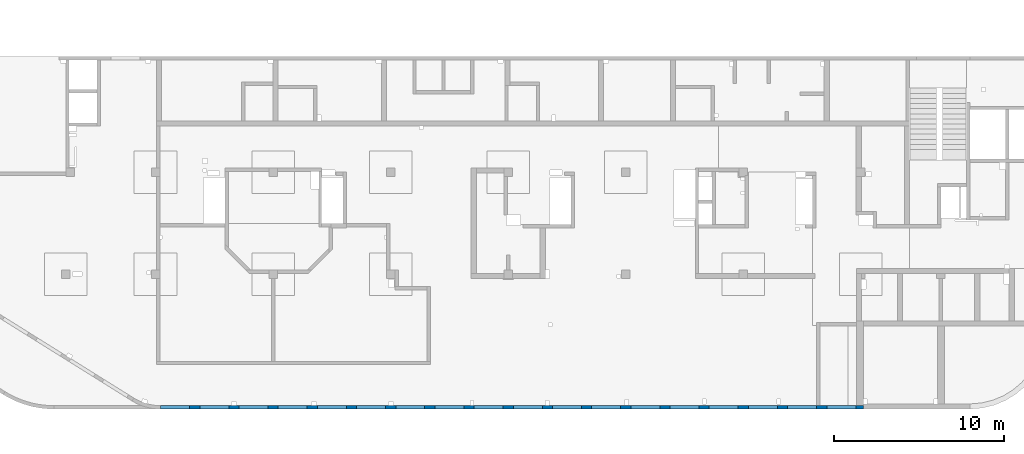
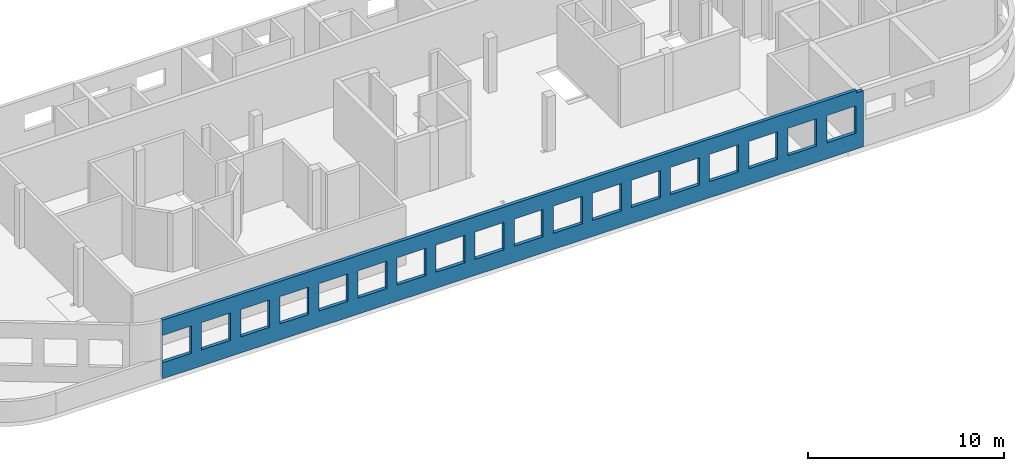
# One storey, part 8 of 10: 1 wall, 18 openings.
"""IFC4 building model written with IfcOpenShell, lengths in millimetres."""

from ifc_helpers import new_model, entity, si_unit, converted_unit, derived_unit, direction, frame, origin, place, context, subcontext, project, spatial, indexed_curve, outline, extrude, polygons, material, type_object, element, save


model = new_model("IFC4")

# Units and contexts
model_context = context("Model", 3, precision=0.01, world=origin(), true_north=direction((6.12303176911189e-17, 1.0)))
plan_context = context("Plan", 3, precision=0.01, world=origin(), true_north=direction((6.12303176911189e-17, 1.0)))
body_context = subcontext(model_context, "Body", "Model", "MODEL_VIEW")
ifc_project = project(units=[si_unit("LENGTHUNIT", "METRE", prefix="MILLI"), si_unit("AREAUNIT", "SQUARE_METRE"), si_unit("VOLUMEUNIT", "CUBIC_METRE"), converted_unit("PLANEANGLEUNIT", "DEGREE", entity("IfcRatioMeasure", 0.0174532925199433), si_unit("PLANEANGLEUNIT", "RADIAN"), dimensions=[0, 0, 0, 0, 0, 0, 0]), si_unit("MASSUNIT", "GRAM", prefix="KILO"), derived_unit("MASSDENSITYUNIT", [(si_unit("MASSUNIT", "GRAM", prefix="KILO"), 1), (si_unit("LENGTHUNIT", "METRE"), -3)]), derived_unit("MOMENTOFINERTIAUNIT", [(si_unit("LENGTHUNIT", "METRE"), 4)]), si_unit("TIMEUNIT", "SECOND"), si_unit("FREQUENCYUNIT", "HERTZ"), si_unit("THERMODYNAMICTEMPERATUREUNIT", "DEGREE_CELSIUS"), derived_unit("THERMALTRANSMITTANCEUNIT", [(si_unit("MASSUNIT", "GRAM", prefix="KILO"), 1), (si_unit("THERMODYNAMICTEMPERATUREUNIT", "KELVIN"), -1), (si_unit("TIMEUNIT", "SECOND"), -3)]), derived_unit("VOLUMETRICFLOWRATEUNIT", [(si_unit("LENGTHUNIT", "METRE"), 3), (si_unit("TIMEUNIT", "SECOND"), -1)]), derived_unit("MASSFLOWRATEUNIT", [(si_unit("MASSUNIT", "GRAM", prefix="KILO"), 1), (si_unit("TIMEUNIT", "SECOND"), -1)]), derived_unit("ROTATIONALFREQUENCYUNIT", [(si_unit("TIMEUNIT", "SECOND"), -1)]), si_unit("ELECTRICCURRENTUNIT", "AMPERE"), si_unit("ELECTRICVOLTAGEUNIT", "VOLT"), si_unit("POWERUNIT", "WATT"), si_unit("FORCEUNIT", "NEWTON", prefix="KILO"), si_unit("ILLUMINANCEUNIT", "LUX"), si_unit("LUMINOUSFLUXUNIT", "LUMEN"), si_unit("LUMINOUSINTENSITYUNIT", "CANDELA"), derived_unit("USERDEFINED", [(si_unit("MASSUNIT", "GRAM", prefix="KILO"), -1), (si_unit("LENGTHUNIT", "METRE"), -2), (si_unit("TIMEUNIT", "SECOND"), 3), (si_unit("LUMINOUSFLUXUNIT", "LUMEN"), 1)]), derived_unit("LINEARVELOCITYUNIT", [(si_unit("LENGTHUNIT", "METRE"), 1), (si_unit("TIMEUNIT", "SECOND"), -1)]), si_unit("PRESSUREUNIT", "PASCAL"), derived_unit("USERDEFINED", [(si_unit("LENGTHUNIT", "METRE"), -2), (si_unit("MASSUNIT", "GRAM", prefix="KILO"), 1), (si_unit("TIMEUNIT", "SECOND"), -2)]), derived_unit("LINEARFORCEUNIT", [(si_unit("MASSUNIT", "GRAM", prefix="KILO"), 1), (si_unit("LENGTHUNIT", "METRE"), 1), (si_unit("TIMEUNIT", "SECOND"), -2), (si_unit("LENGTHUNIT", "METRE"), -1)]), derived_unit("PLANARFORCEUNIT", [(si_unit("MASSUNIT", "GRAM", prefix="KILO"), 1), (si_unit("LENGTHUNIT", "METRE"), 1), (si_unit("TIMEUNIT", "SECOND"), -2), (si_unit("LENGTHUNIT", "METRE"), -2)])], contexts=[model_context, plan_context])

# Site, building, storey
site_placement = place(None, origin())
site = spatial("IfcSite", under=ifc_project, at=site_placement, CompositionType="ELEMENT")
building_placement = place(site_placement, origin())
building = spatial("IfcBuilding", under=site, at=building_placement, CompositionType="ELEMENT")
storey_placement = place(building_placement, frame((0.0, 0.0, 4200.0)))
storey = spatial("IfcBuildingStorey", under=building, at=storey_placement, Name="02", CompositionType="ELEMENT", Elevation=4200.0)

# Wall, openings
ifc_material = material()
wall_type = type_object("IfcWallType", Name=":ADSK_ 25_200", PredefinedType="STANDARD")
wall_placement = place(storey_placement, frame((21465.0, -100.0, -150.0)))
wall = element("IfcWall", 1, at=wall_placement, inside=storey, type_object=wall_type, material=ifc_material, Name=":ADSK_ 25_200", ObjectType=":ADSK_ 25_200", PredefinedType="NOTDEFINED", context=body_context, shape_type="Tessellation", body=[
    polygons([(5.00000000005149, -100.0, 2700.0), (1705.00000000005, -100.0, 2700.0), (1705.00000000005, -100.0, 1000.00000000001), (5.00000000005149, -100.0, 1000.00000000001), (2305.00000000005, -100.0, 2700.0), (4005.00000000005, -100.0, 2700.0), (4005.00000000005, -100.0, 1000.00000000001), (2305.00000000005, -100.0, 1000.00000000001), (4605.00000000006, -100.0, 2700.0), (6305.00000000006, -100.0, 2700.0), (6305.00000000006, -100.0, 1000.00000000001), (4605.00000000006, -100.0, 1000.00000000001), (6905.00000000004, -100.0, 2700.0), (8605.00000000004, -100.0, 2700.0), (8605.00000000004, -100.0, 1000.00000000001), (6905.00000000004, -100.0, 1000.00000000001), (9205.00000000005, -100.0, 2700.0), (10905.0000000001, -100.0, 2700.0), (10905.0000000001, -100.0, 1000.00000000001), (9205.00000000005, -100.0, 1000.00000000001), (11505.0000000001, -100.0, 2700.0), (13205.0000000001, -100.0, 2700.0), (13205.0000000001, -100.0, 1000.00000000001), (11505.0000000001, -100.0, 1000.00000000001), (13805.0, -100.0, 2700.0), (15505.0, -100.0, 2700.0), (15505.0, -100.0, 1000.00000000001), (13805.0, -100.0, 1000.00000000001), (16105.0000000001, -100.0, 2700.0), (17805.0000000001, -100.0, 2700.0), (17805.0000000001, -100.0, 1000.00000000001), (16105.0000000001, -100.0, 1000.00000000001), (18405.0000000001, -100.0, 2700.0), (20105.0, -100.0, 2700.0), (20105.0, -100.0, 1000.00000000001), (18405.0000000001, -100.0, 1000.00000000001), (23005.0, -100.0, 2700.0), (24705.0, -100.0, 2700.0), (24705.0, -100.0, 1000.00000000001), (23005.0, -100.0, 1000.00000000001), (25305.0000000001, -100.0, 2700.0), (27005.0000000001, -100.0, 2700.0), (27005.0000000001, -100.0, 1000.00000000001), (25305.0000000001, -100.0, 1000.00000000001), (27605.0, -100.0, 2700.0), (29305.0, -100.0, 2700.0), (29305.0, -100.0, 1000.00000000001), (27605.0, -100.0, 1000.00000000001), (29905.0000000001, -100.0, 2700.0), (31605.0000000001, -100.0, 2700.0), (31605.0000000001, -100.0, 1000.00000000001), (29905.0000000001, -100.0, 1000.00000000001), (32205.0000000001, -100.0, 2700.0), (33905.0000000001, -100.0, 2700.0), (33905.0000000001, -100.0, 1000.00000000001), (32205.0000000001, -100.0, 1000.00000000001), (34505.0, -100.0, 2700.0), (36205.0, -100.0, 2700.0), (36205.0, -100.0, 1000.00000000001), (34505.0, -100.0, 1000.00000000001), (36805.0, -100.0, 2700.0), (38505.0000000001, -100.0, 2700.0), (38505.0000000001, -100.0, 1000.00000000001), (36805.0, -100.0, 1000.00000000001), (39105.0000000001, -100.0, 2700.0), (40805.0000000001, -100.0, 2700.0), (40805.0000000001, -100.0, 1000.00000000001), (39105.0000000001, -100.0, 1000.00000000001), (20705.0, -100.0, 2700.0), (22405.0, -100.0, 2700.0), (22405.0, -100.0, 1000.00000000001), (20705.0, -100.0, 1000.00000000001), (6.46057117472606e-13, -100.0, 5.41433564649196e-13), (40355.0, -100.0, 5.41433564649196e-13), (41255.0, -100.0, 5.41433564649196e-13), (41255.0, -100.0, 3500.0), (40855.0, -99.9999999999864, 3500.0), (40855.0, -100.0, 3650.0), (6.46057117472606e-13, -100.0, 3650.0), (6.46057117472606e-13, -100.0, 1310.0), (6.46057117472606e-13, -100.0, 150.000000000001), (41255.0, 100.0, 5.41433564649196e-13), (40855.0, 100.0, 5.41433564649196e-13), (38705.0, 100.0, 5.41433564649196e-13), (38505.0, 100.0, 5.41433564649196e-13), (22805.0, 100.0, 5.41433564649196e-13), (22605.0, 100.0, 5.41433564649196e-13), (18380.0, 100.0, 5.41433564649196e-13), (18180.0, 100.0, 5.41433564649196e-13), (13665.0, 100.0, 5.41433564649196e-13), (13365.0, 100.0, 5.41433564649196e-13), (9155.0, 100.0, 5.41433564649196e-13), (8855.0, 100.0, 5.41433564649196e-13), (4455.0, 100.0, 5.41433564649196e-13), (4155.0, 100.0, 5.41433564649196e-13), (2.49908057411173e-18, 100.0, 5.41433564649196e-13), (2.4990805740975e-18, 100.0, 150.000000000001), (2.4990805740975e-18, 100.0, 1310.0), (2.49908057411173e-18, 100.0, 3650.0), (13574.9996657992, 100.0, 3650.0), (13774.9996657992, 100.0, 3650.0), (18005.0, 100.0, 3650.0), (18205.0, 100.0, 3650.0), (38505.0, 100.0, 3650.0), (38705.0, 100.0, 3650.0), (40855.0, 100.0, 3650.0), (40855.0, 99.9999999999999, 3500.0), (41255.0, 100.0, 3500.0), (1705.00000000005, 100.000000000321, 2700.0), (5.00000000005084, 100.000000000321, 2700.0), (5.00000000005084, 100.000000000321, 1000.00000000001), (1705.00000000005, 100.000000000321, 1000.00000000001), (4005.00000000005, 100.000000000321, 2700.0), (2305.00000000005, 100.000000000321, 2700.0), (2305.00000000005, 100.000000000321, 1000.00000000001), (4005.00000000005, 100.000000000321, 1000.00000000001), (6305.00000000006, 100.000000000321, 2700.0), (4605.00000000006, 100.000000000321, 2700.0), (4605.00000000006, 100.000000000321, 1000.00000000001), (6305.00000000006, 100.000000000321, 1000.00000000001), (8605.00000000004, 100.000000000321, 2700.0), (6905.00000000004, 100.000000000321, 2700.0), (6905.00000000004, 100.000000000321, 1000.00000000001), (8605.00000000004, 100.000000000321, 1000.00000000001), (10905.0000000001, 100.000000000321, 2700.0), (9205.00000000005, 100.000000000321, 2700.0), (9205.00000000005, 100.000000000321, 1000.00000000001), (10905.0000000001, 100.000000000321, 1000.00000000001), (13205.0000000001, 100.000000000321, 2700.0), (11505.0000000001, 100.000000000321, 2700.0), (11505.0000000001, 100.000000000321, 1000.00000000001), (13205.0000000001, 100.000000000321, 1000.00000000001), (15505.0, 100.000000000321, 2700.0), (13805.0, 100.000000000321, 2700.0), (13805.0, 100.000000000321, 1000.00000000001), (15505.0, 100.000000000321, 1000.00000000001), (17805.0000000001, 100.000000000321, 2700.0), (16105.0000000001, 100.000000000321, 2700.0), (16105.0000000001, 100.000000000321, 1000.00000000001), (17805.0000000001, 100.000000000321, 1000.00000000001), (20105.0, 100.000000000321, 2700.0), (18405.0000000001, 100.000000000321, 2700.0), (18405.0000000001, 100.000000000321, 1000.00000000001), (20105.0, 100.000000000321, 1000.00000000001), (24705.0, 100.000000000321, 2700.0), (23005.0, 100.000000000321, 2700.0), (23005.0, 100.000000000321, 1000.00000000001), (24705.0, 100.000000000321, 1000.00000000001), (27005.0000000001, 100.000000000321, 2700.0), (25305.0000000001, 100.000000000321, 2700.0), (25305.0000000001, 100.000000000321, 1000.00000000001), (27005.0000000001, 100.000000000321, 1000.00000000001), (29305.0, 100.000000000321, 2700.0), (27605.0, 100.000000000321, 2700.0), (27605.0, 100.000000000321, 1000.00000000001), (29305.0, 100.000000000321, 1000.00000000001), (31605.0000000001, 100.000000000321, 2700.0), (29905.0000000001, 100.000000000321, 2700.0), (29905.0000000001, 100.000000000321, 1000.00000000001), (31605.0000000001, 100.000000000321, 1000.00000000001), (33905.0000000001, 100.000000000321, 2700.0), (32205.0000000001, 100.000000000321, 2700.0), (32205.0000000001, 100.000000000321, 1000.00000000001), (33905.0000000001, 100.000000000321, 1000.00000000001), (36205.0, 100.000000000321, 2700.0), (34505.0, 100.000000000321, 2700.0), (34505.0, 100.000000000321, 1000.00000000001), (36205.0, 100.000000000321, 1000.00000000001), (38505.0000000001, 100.000000000321, 2700.0), (36805.0, 100.000000000321, 2700.0), (36805.0, 100.000000000321, 1000.00000000001), (38505.0000000001, 100.000000000321, 1000.00000000001), (40805.0000000001, 100.000000000321, 2700.0), (39105.0000000001, 100.000000000321, 2700.0), (39105.0000000001, 100.000000000321, 1000.00000000001), (40805.0000000001, 100.000000000321, 1000.00000000001), (22405.0, 100.000000000321, 2700.0), (20705.0, 100.000000000321, 2700.0), (20705.0, 100.000000000321, 1000.00000000001), (22405.0, 100.000000000321, 1000.00000000001)], [[[73, 74, 75, 76, 77, 78, 79, 80, 81], [1, 2, 3, 4], [5, 6, 7, 8], [9, 10, 11, 12], [13, 14, 15, 16], [17, 18, 19, 20], [21, 22, 23, 24], [25, 26, 27, 28], [29, 30, 31, 32], [33, 34, 35, 36], [37, 38, 39, 40], [41, 42, 43, 44], [45, 46, 47, 48], [49, 50, 51, 52], [53, 54, 55, 56], [57, 58, 59, 60], [61, 62, 63, 64], [65, 66, 67, 68], [69, 70, 71, 72]], [[82, 83, 84, 85, 86, 87, 88, 89, 90, 91, 92, 93, 94, 95, 96, 97, 98, 99, 100, 101, 102, 103, 104, 105, 106, 107, 108], [109, 110, 111, 112], [113, 114, 115, 116], [117, 118, 119, 120], [121, 122, 123, 124], [125, 126, 127, 128], [129, 130, 131, 132], [133, 134, 135, 136], [137, 138, 139, 140], [141, 142, 143, 144], [145, 146, 147, 148], [149, 150, 151, 152], [153, 154, 155, 156], [157, 158, 159, 160], [161, 162, 163, 164], [165, 166, 167, 168], [169, 170, 171, 172], [173, 174, 175, 176], [177, 178, 179, 180]], [[75, 74, 73, 96, 95, 94, 93, 92, 91, 90, 89, 88, 87, 86, 85, 84, 83, 82]], [[99, 79, 78, 106, 105, 104, 103, 102, 101, 100]], [[75, 82, 108, 76]], [[110, 109, 2, 1]], [[110, 1, 4, 111]], [[111, 4, 3, 112]], [[2, 109, 112, 3]], [[114, 113, 6, 5]], [[114, 5, 8, 115]], [[115, 8, 7, 116]], [[6, 113, 116, 7]], [[118, 117, 10, 9]], [[118, 9, 12, 119]], [[119, 12, 11, 120]], [[10, 117, 120, 11]], [[122, 121, 14, 13]], [[122, 13, 16, 123]], [[123, 16, 15, 124]], [[14, 121, 124, 15]], [[126, 125, 18, 17]], [[126, 17, 20, 127]], [[127, 20, 19, 128]], [[18, 125, 128, 19]], [[130, 129, 22, 21]], [[130, 21, 24, 131]], [[131, 24, 23, 132]], [[22, 129, 132, 23]], [[134, 133, 26, 25]], [[134, 25, 28, 135]], [[135, 28, 27, 136]], [[26, 133, 136, 27]], [[138, 137, 30, 29]], [[138, 29, 32, 139]], [[139, 32, 31, 140]], [[30, 137, 140, 31]], [[142, 141, 34, 33]], [[142, 33, 36, 143]], [[143, 36, 35, 144]], [[34, 141, 144, 35]], [[146, 145, 38, 37]], [[146, 37, 40, 147]], [[147, 40, 39, 148]], [[38, 145, 148, 39]], [[150, 149, 42, 41]], [[150, 41, 44, 151]], [[151, 44, 43, 152]], [[42, 149, 152, 43]], [[154, 153, 46, 45]], [[154, 45, 48, 155]], [[155, 48, 47, 156]], [[46, 153, 156, 47]], [[158, 157, 50, 49]], [[158, 49, 52, 159]], [[159, 52, 51, 160]], [[50, 157, 160, 51]], [[162, 161, 54, 53]], [[162, 53, 56, 163]], [[163, 56, 55, 164]], [[54, 161, 164, 55]], [[166, 165, 58, 57]], [[166, 57, 60, 167]], [[167, 60, 59, 168]], [[58, 165, 168, 59]], [[170, 169, 62, 61]], [[170, 61, 64, 171]], [[171, 64, 63, 172]], [[62, 169, 172, 63]], [[174, 173, 66, 65]], [[174, 65, 68, 175]], [[175, 68, 67, 176]], [[66, 173, 176, 67]], [[178, 177, 70, 69]], [[178, 69, 72, 179]], [[179, 72, 71, 180]], [[70, 177, 180, 71]], [[79, 99, 98, 97, 96, 73, 81, 80]], [[107, 77, 76, 108]], [[77, 107, 106, 78]]], closed=True),
])
placement = place(wall_placement, frame((-21465.0, 100.0, 150.0)))
element("IfcOpeningElement", 2, at=placement, cuts=wall, Name=":ADSK_ 25_200", PredefinedType="OPENING", context=body_context, shape_type="SweptSolid", body=[
    extrude(outline(indexed_curve([(-849.999999999994, -850.000000000006), (849.999999999993, -850.000000000006), (849.999999999993, 849.999999999997), (-849.999999999994, 849.999999999997), (-849.999999999994, -850.000000000006)], self_intersect=False)), frame((61420.0, -200.0, 1700.0), z_axis=(0.0, 1.0, 0.0), x_axis=(0.0, 0.0, -1.0)), (0.0, 0.0, 1.0), 200.000000000962),
])
element("IfcOpeningElement", 3, at=placement, cuts=wall, Name=":ADSK_ 25_200", PredefinedType="OPENING", context=body_context, shape_type="SweptSolid", body=[
    extrude(outline(indexed_curve([(-849.999999999994, -849.999999999997), (849.999999999993, -849.999999999997), (849.999999999993, 850.000000000006), (-849.999999999994, 850.000000000006), (-849.999999999994, -849.999999999997)], self_intersect=False)), frame((59120.0, -200.0, 1700.0), z_axis=(0.0, 1.0, 0.0), x_axis=(0.0, 0.0, -1.0)), (0.0, 0.0, 1.0), 200.000000000962),
])
element("IfcOpeningElement", 4, at=placement, cuts=wall, Name=":ADSK_ 25_200", PredefinedType="OPENING", context=body_context, shape_type="SweptSolid", body=[
    extrude(outline(indexed_curve([(-849.999999999994, -850.000000000006), (849.999999999993, -850.000000000006), (849.999999999993, 849.999999999997), (-849.999999999994, 849.999999999997), (-849.999999999994, -850.000000000006)], self_intersect=False)), frame((56820.0, -200.0, 1700.0), z_axis=(0.0, 1.0, 0.0), x_axis=(0.0, 0.0, -1.0)), (0.0, 0.0, 1.0), 200.000000000962),
])
element("IfcOpeningElement", 5, at=placement, cuts=wall, Name=":ADSK_ 25_200", PredefinedType="OPENING", context=body_context, shape_type="SweptSolid", body=[
    extrude(outline(indexed_curve([(-849.999999999994, -849.999999999997), (849.999999999993, -849.999999999997), (849.999999999993, 850.000000000006), (-849.999999999994, 850.000000000006), (-849.999999999994, -849.999999999997)], self_intersect=False)), frame((54520.0, -200.0, 1700.0), z_axis=(0.0, 1.0, 0.0), x_axis=(0.0, 0.0, -1.0)), (0.0, 0.0, 1.0), 200.000000000962),
])
element("IfcOpeningElement", 6, at=placement, cuts=wall, Name=":ADSK_ 25_200", PredefinedType="OPENING", context=body_context, shape_type="SweptSolid", body=[
    extrude(outline(indexed_curve([(-849.999999999994, -849.999999999997), (849.999999999993, -849.999999999997), (849.999999999993, 850.000000000006), (-849.999999999994, 850.000000000006), (-849.999999999994, -849.999999999997)], self_intersect=False)), frame((52220.0, -200.0, 1700.0), z_axis=(0.0, 1.0, 0.0), x_axis=(0.0, 0.0, -1.0)), (0.0, 0.0, 1.0), 200.000000000962),
])
element("IfcOpeningElement", 7, at=placement, cuts=wall, Name=":ADSK_ 25_200", PredefinedType="OPENING", context=body_context, shape_type="SweptSolid", body=[
    extrude(outline(indexed_curve([(-849.999999999994, -850.000000000006), (849.999999999993, -850.000000000006), (849.999999999993, 849.999999999997), (-849.999999999994, 849.999999999997), (-849.999999999994, -850.000000000006)], self_intersect=False)), frame((49920.0, -200.0, 1700.0), z_axis=(0.0, 1.0, 0.0), x_axis=(0.0, 0.0, -1.0)), (0.0, 0.0, 1.0), 200.000000000962),
])
element("IfcOpeningElement", 8, at=placement, cuts=wall, Name=":ADSK_ 25_200", PredefinedType="OPENING", context=body_context, shape_type="SweptSolid", body=[
    extrude(outline(indexed_curve([(-849.999999999994, -849.999999999997), (849.999999999993, -849.999999999997), (849.999999999993, 850.000000000006), (-849.999999999994, 850.000000000006), (-849.999999999994, -849.999999999997)], self_intersect=False)), frame((47620.0, -200.0, 1700.0), z_axis=(0.0, 1.0, 0.0), x_axis=(0.0, 0.0, -1.0)), (0.0, 0.0, 1.0), 200.000000000962),
])
element("IfcOpeningElement", 9, at=placement, cuts=wall, Name=":ADSK_ 25_200", PredefinedType="OPENING", context=body_context, shape_type="SweptSolid", body=[
    extrude(outline(indexed_curve([(-849.999999999994, -850.000000000006), (849.999999999993, -850.000000000006), (849.999999999993, 849.999999999997), (-849.999999999994, 849.999999999997), (-849.999999999994, -850.000000000006)], self_intersect=False)), frame((45320.0, -200.0, 1700.0), z_axis=(0.0, 1.0, 0.0), x_axis=(0.0, 0.0, -1.0)), (0.0, 0.0, 1.0), 200.000000000962),
])
element("IfcOpeningElement", 10, at=placement, cuts=wall, Name=":ADSK_ 25_200", PredefinedType="OPENING", context=body_context, shape_type="SweptSolid", body=[
    extrude(outline(indexed_curve([(-849.999999999994, -850.000000000006), (849.999999999993, -850.000000000006), (849.999999999993, 849.999999999997), (-849.999999999994, 849.999999999997), (-849.999999999994, -850.000000000006)], self_intersect=False)), frame((40720.0, -200.0, 1700.0), z_axis=(0.0, 1.0, 0.0), x_axis=(0.0, 0.0, -1.0)), (0.0, 0.0, 1.0), 200.000000000962),
])
element("IfcOpeningElement", 11, at=placement, cuts=wall, Name=":ADSK_ 25_200", PredefinedType="OPENING", context=body_context, shape_type="SweptSolid", body=[
    extrude(outline(indexed_curve([(-849.999999999994, -850.000000000002), (849.999999999993, -850.000000000002), (849.999999999993, 849.999999999997), (-849.999999999994, 849.999999999997), (-849.999999999994, -850.000000000002)], self_intersect=False)), frame((38420.0, -200.0, 1700.0), z_axis=(0.0, 1.0, 0.0), x_axis=(0.0, 0.0, -1.0)), (0.0, 0.0, 1.0), 200.000000000962),
])
element("IfcOpeningElement", 12, at=placement, cuts=wall, Name=":ADSK_ 25_200", PredefinedType="OPENING", context=body_context, shape_type="SweptSolid", body=[
    extrude(outline(indexed_curve([(-849.999999999994, -850.000000000002), (849.999999999993, -850.000000000002), (849.999999999993, 849.999999999997), (-849.999999999994, 849.999999999997), (-849.999999999994, -850.000000000002)], self_intersect=False)), frame((36120.0, -200.0, 1700.0), z_axis=(0.0, 1.0, 0.0), x_axis=(0.0, 0.0, -1.0)), (0.0, 0.0, 1.0), 200.000000000962),
])
element("IfcOpeningElement", 13, at=placement, cuts=wall, Name=":ADSK_ 25_200", PredefinedType="OPENING", context=body_context, shape_type="SweptSolid", body=[
    extrude(outline(indexed_curve([(-849.999999999994, -850.000000000002), (849.999999999993, -850.000000000002), (849.999999999993, 849.999999999997), (-849.999999999994, 849.999999999997), (-849.999999999994, -850.000000000002)], self_intersect=False)), frame((33820.0, -200.0, 1700.0), z_axis=(0.0, 1.0, 0.0), x_axis=(0.0, 0.0, -1.0)), (0.0, 0.0, 1.0), 200.000000000962),
])
element("IfcOpeningElement", 14, at=placement, cuts=wall, Name=":ADSK_ 25_200", PredefinedType="OPENING", context=body_context, shape_type="SweptSolid", body=[
    extrude(outline(indexed_curve([(-849.999999999994, -849.999999999997), (849.999999999993, -849.999999999997), (849.999999999993, 850.000000000002), (-849.999999999994, 850.000000000002), (-849.999999999994, -849.999999999997)], self_intersect=False)), frame((31520.0, -200.0, 1700.0), z_axis=(0.0, 1.0, 0.0), x_axis=(0.0, 0.0, -1.0)), (0.0, 0.0, 1.0), 200.000000000962),
])
element("IfcOpeningElement", 15, at=placement, cuts=wall, Name=":ADSK_ 25_200", PredefinedType="OPENING", context=body_context, shape_type="SweptSolid", body=[
    extrude(outline(indexed_curve([(-849.999999999994, -849.999999999997), (849.999999999993, -849.999999999997), (849.999999999993, 850.000000000002), (-849.999999999994, 850.000000000002), (-849.999999999994, -849.999999999997)], self_intersect=False)), frame((29220.0, -200.0, 1700.0), z_axis=(0.0, 1.0, 0.0), x_axis=(0.0, 0.0, -1.0)), (0.0, 0.0, 1.0), 200.000000000962),
])
element("IfcOpeningElement", 16, at=placement, cuts=wall, Name=":ADSK_ 25_200", PredefinedType="OPENING", context=body_context, shape_type="SweptSolid", body=[
    extrude(outline(indexed_curve([(-849.999999999994, -850.000000000002), (849.999999999993, -850.000000000002), (849.999999999993, 849.999999999997), (-849.999999999994, 849.999999999997), (-849.999999999994, -850.000000000002)], self_intersect=False)), frame((26920.0, -200.0, 1700.0), z_axis=(0.0, 1.0, 0.0), x_axis=(0.0, 0.0, -1.0)), (0.0, 0.0, 1.0), 200.000000000962),
])
element("IfcOpeningElement", 17, at=placement, cuts=wall, Name=":ADSK_ 25_200", PredefinedType="OPENING", context=body_context, shape_type="SweptSolid", body=[
    extrude(outline(indexed_curve([(-849.999999999994, -850.000000000002), (849.999999999993, -850.000000000002), (849.999999999993, 849.999999999997), (-849.999999999994, 849.999999999997), (-849.999999999994, -850.000000000002)], self_intersect=False)), frame((24620.0, -200.0, 1700.0), z_axis=(0.0, 1.0, 0.0), x_axis=(0.0, 0.0, -1.0)), (0.0, 0.0, 1.0), 200.000000000962),
])
element("IfcOpeningElement", 18, at=placement, cuts=wall, Name=":ADSK_ 25_200", PredefinedType="OPENING", context=body_context, shape_type="SweptSolid", body=[
    extrude(outline(indexed_curve([(-849.999999999994, -850.000000000002), (849.999999999993, -850.000000000002), (849.999999999993, 849.999999999997), (-849.999999999994, 849.999999999997), (-849.999999999994, -850.000000000002)], self_intersect=False)), frame((22320.0, -200.0, 1700.0), z_axis=(0.0, 1.0, 0.0), x_axis=(0.0, 0.0, -1.0)), (0.0, 0.0, 1.0), 200.000000000962),
])
element("IfcOpeningElement", 19, at=placement, cuts=wall, Name=":ADSK_ 25_200", PredefinedType="OPENING", context=body_context, shape_type="SweptSolid", body=[
    extrude(outline(indexed_curve([(-849.999999999994, -849.999999999997), (849.999999999993, -849.999999999997), (849.999999999993, 850.000000000006), (-849.999999999994, 850.000000000006), (-849.999999999994, -849.999999999997)], self_intersect=False)), frame((43020.0, -200.0, 1700.0), z_axis=(0.0, 1.0, 0.0), x_axis=(0.0, 0.0, -1.0)), (0.0, 0.0, 1.0), 200.000000000962),
])

save(model, "model.ifc")
